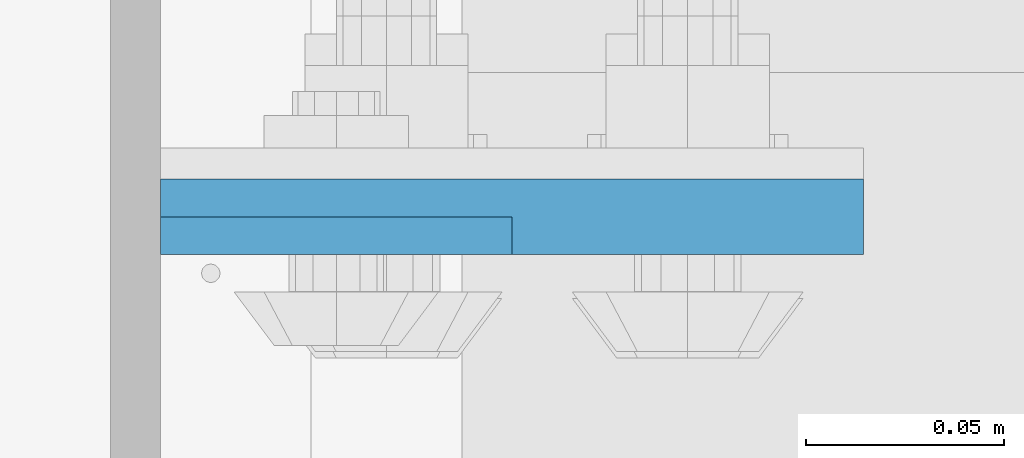
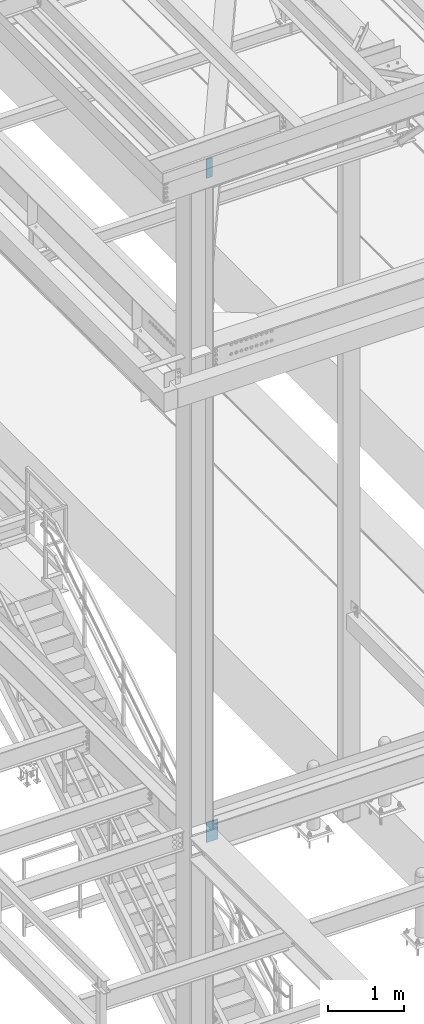
# One storey, part 1454 of 3843: 2 columns, 1 element without a shape of its own.
"""IFC2X3 building model written with IfcOpenShell, lengths in millimetres."""

from ifc_helpers import new_model, si_unit, frame, origin_with_axes, place, context, subcontext, project, spatial, faceted_brep, material, type_object, element, aggregate, save


model = new_model("IFC2X3")

# Units and contexts
model_context = context("Model", 3, precision=1e-05, world=origin_with_axes())
body_context = subcontext(model_context, "Body", "Model", "MODEL_VIEW")
ifc_project = project(units=[si_unit("LENGTHUNIT", "METRE", prefix="MILLI"), si_unit("AREAUNIT", "SQUARE_METRE"), si_unit("VOLUMEUNIT", "CUBIC_METRE"), si_unit("MASSUNIT", "GRAM", prefix="KILO"), si_unit("TIMEUNIT", "SECOND"), si_unit("PLANEANGLEUNIT", "RADIAN"), si_unit("SOLIDANGLEUNIT", "STERADIAN"), si_unit("THERMODYNAMICTEMPERATUREUNIT", "DEGREE_CELSIUS"), si_unit("LUMINOUSINTENSITYUNIT", "LUMEN")], contexts=[model_context])

# Site, building, storey
site_placement = place(None, origin_with_axes())
site = spatial("IfcSite", under=ifc_project, at=site_placement, CompositionType="ELEMENT")
building_placement = place(site_placement, origin_with_axes())
building = spatial("IfcBuilding", under=site, at=building_placement, Name="Undefined", CompositionType="ELEMENT")
storey_placement = place(building_placement, origin_with_axes())
storey = spatial("IfcBuildingStorey", under=building, at=storey_placement, Name="Undefined", CompositionType="ELEMENT", Elevation=0.0)

# Assembly, columns
assembly_placement = place(storey_placement, origin_with_axes())
assembly = element("IfcElementAssembly", 1, at=assembly_placement, inside=storey, Name="COLUMN", AssemblyPlace="NOTDEFINED", PredefinedType="RIGID_FRAME")
ifc_material = material(Name="STEEL/A572-50")
column_type_1 = type_object("IfcColumnType", PredefinedType="NOTDEFINED")
column_1_placement = place(assembly_placement, frame((36842.7, 25630.1875, 34461.45), z_axis=(-1.0, 0.0, 0.0), x_axis=(0.0, 0.0, 1.0)))
column_1 = element("IfcColumn", 2, at=column_1_placement, type_object=column_type_1, material=ifc_material, Name="PLATE", context=body_context, shape_type="Brep", body=[
    faceted_brep([(0.0, 9.52500000000146, -88.9000000000015), (0.0, 9.52500000000146, 88.9000000000015), (317.5, 9.52500000000146, 88.9000000000015), (317.5, 9.52500000000146, -88.9000000000015), (0.0, -9.52500000000146, 88.9000000000015), (317.5, -9.52500000000146, 88.9000000000015), (0.0, -9.52500000000146, -88.9000000000015), (317.5, -9.52500000000146, -88.9000000000015)], [[[0, 1, 2, 3]], [[1, 4, 5, 2]], [[4, 6, 7, 5]], [[6, 0, 3, 7]], [[5, 7, 3, 2]], [[6, 4, 1, 0]]]),
])
column_type_2 = type_object("IfcColumnType", PredefinedType="NOTDEFINED")
column_2_placement = place(assembly_placement, frame((36798.2499999997, 25625.425, 45080.1771057863), z_axis=(-1.0, 0.0, 0.0), x_axis=(0.0, 0.0, 1.0)))
column_2 = element("IfcColumn", 3, at=column_2_placement, type_object=column_type_2, material=ifc_material, Name="PLATE", context=body_context, shape_type="Brep", body=[
    faceted_brep([(0.0, 4.76249999999709, -44.4500000000007), (0.0, 4.76249999999709, 44.4500000000007), (304.799999999996, 4.76249999999709, 44.4500000000007), (304.799999999996, 4.76249999999709, -44.4500000000007), (0.0, -4.76249999999709, 44.4500000000007), (304.799999999996, -4.76249999999709, 44.4500000000007), (0.0, -4.76249999999709, -44.4500000000007), (304.799999999996, -4.76249999999709, -44.4500000000007)], [[[0, 1, 2, 3]], [[1, 4, 5, 2]], [[4, 6, 7, 5]], [[6, 0, 3, 7]], [[5, 7, 3, 2]], [[6, 4, 1, 0]]]),
])
aggregate(assembly, [column_2, column_1])

save(model, "model.ifc")
